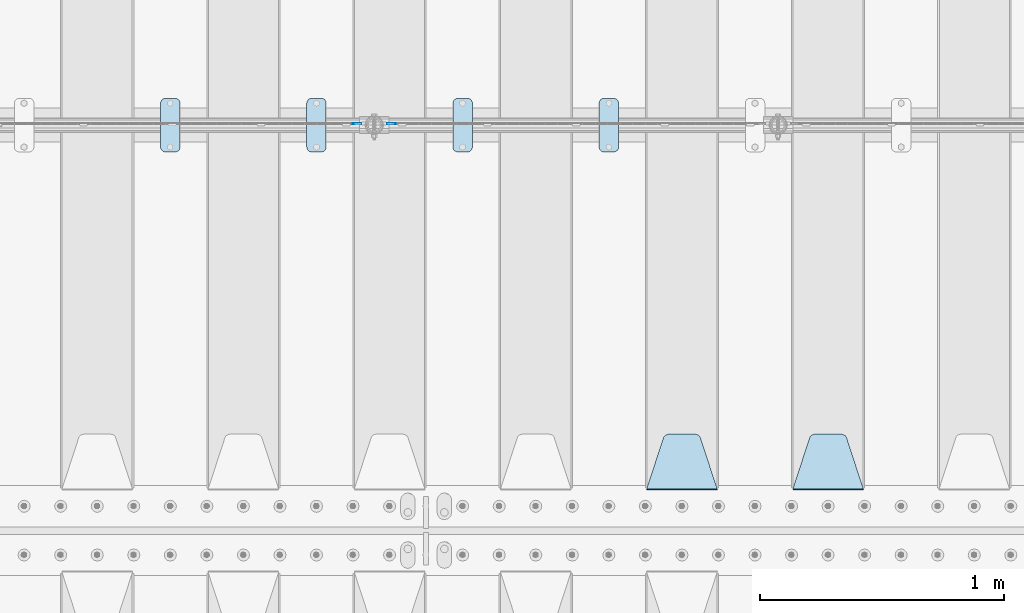
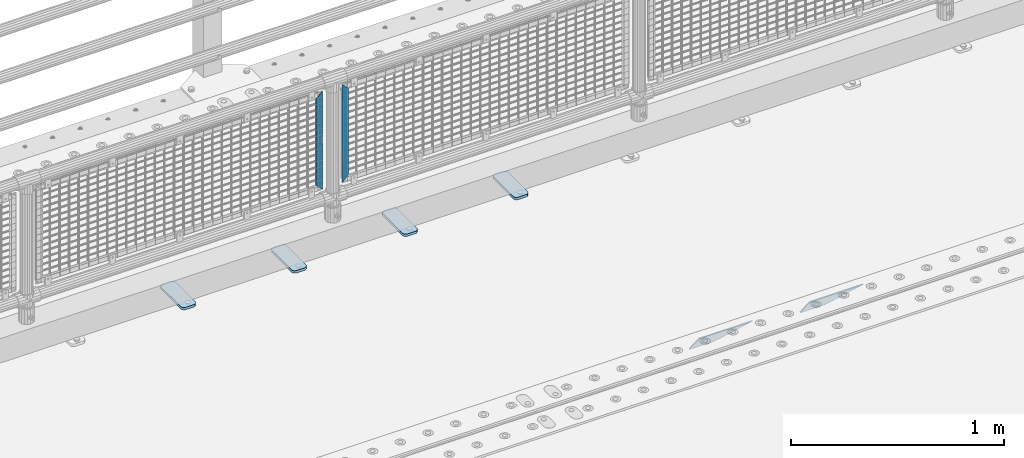
# One storey, part 161 of 193: 8 plates.
"""IFC2X3 building model written with IfcOpenShell, lengths in millimetres."""

from ifc_helpers import new_model, si_unit, frame, origin_with_axes, place, context, subcontext, project, spatial, faceted_brep, material, type_object, element, save


model = new_model("IFC2X3")

# Units and contexts
model_context = context("Model", 3, precision=1e-05, world=origin_with_axes())
body_context = subcontext(model_context, "Body", "Model", "MODEL_VIEW")
ifc_project = project(units=[si_unit("LENGTHUNIT", "METRE", prefix="MILLI"), si_unit("AREAUNIT", "SQUARE_METRE"), si_unit("VOLUMEUNIT", "CUBIC_METRE"), si_unit("MASSUNIT", "GRAM", prefix="KILO"), si_unit("TIMEUNIT", "SECOND"), si_unit("PLANEANGLEUNIT", "RADIAN"), si_unit("SOLIDANGLEUNIT", "STERADIAN"), si_unit("THERMODYNAMICTEMPERATUREUNIT", "DEGREE_CELSIUS"), si_unit("LUMINOUSINTENSITYUNIT", "LUMEN")], contexts=[model_context])

# Site, building, storey
site_placement = place(None, origin_with_axes())
site = spatial("IfcSite", under=ifc_project, at=site_placement, CompositionType="ELEMENT")
building_placement = place(site_placement, origin_with_axes())
building = spatial("IfcBuilding", under=site, at=building_placement, Name="Standard", CompositionType="ELEMENT")
storey_placement = place(building_placement, origin_with_axes())
storey = spatial("IfcBuildingStorey", under=building, at=storey_placement, Name="Undefined", CompositionType="ELEMENT", Elevation=0.0)

# Plates
ifc_material_1 = material(Name="STEEL/S355N")
plate_type_1 = type_object("IfcPlateType", PredefinedType="NOTDEFINED")
plate_1_placement = place(storey_placement, frame((-36505.0, 27168.232233047, -1.76776695296758), z_axis=(0.0, 0.707106781186547, -0.707106781186548), x_axis=(-1.0, 0.0, 0.0)))
element("IfcPlate", 1, at=plate_1_placement, inside=storey, type_object=plate_type_1, material=ifc_material_1, context=body_context, shape_type="Brep", body=[
    faceted_brep([(0.0, -2.5, 0.0), (69.345504679477, -2.50000000000364, 300.171731424831), (69.345504679477, 2.49999999999636, 300.171731424831), (0.0, 2.5, 0.0), (70.9274061199576, -2.50000000000364, 304.897442415397), (70.9274061199576, 2.49999999999636, 304.897442415397), (73.3818627772307, -2.50000000000364, 309.234538108529), (73.3818627772307, 2.49999999999636, 309.234538108529), (76.6187032999551, -2.50000000000728, 313.023683126103), (76.6187032999551, 2.49999999999636, 313.023683126103), (80.5190132704993, -2.50000000000364, 316.125672595372), (80.5190132704993, 2.49999999999636, 316.125672595368), (84.9395038596849, -2.50000000000364, 318.426546230472), (84.9395038596849, 2.49999999999636, 318.426546230476), (89.7177759439219, -2.50000000000364, 319.841774983273), (89.7177759439219, 2.49999999999636, 319.841774983277), (94.678286292652, -2.50000000000364, 320.319366455074), (94.678286292652, 2.49999999999636, 320.319366455074), (195.321713707348, -2.50000000000364, 320.319366455074), (195.321713707348, 2.49999999999636, 320.319366455074), (200.282224056078, -2.50000000000364, 319.841774983273), (200.282224056078, 2.49999999999636, 319.841774983277), (205.060496140315, -2.50000000000364, 318.426546230472), (205.060496140315, 2.49999999999636, 318.426546230472), (209.480986729501, -2.50000000000364, 316.125672595372), (209.480986729501, 2.49999999999636, 316.125672595368), (213.381296700045, -2.50000000000728, 313.023683126103), (213.381296700045, 2.49999999999272, 313.023683126103), (216.618137222769, -2.50000000000364, 309.234538108525), (216.618137222769, 2.49999999999636, 309.234538108522), (219.072593880042, -2.50000000000364, 304.897442415397), (219.072593880042, 2.49999999999636, 304.897442415397), (220.654495320523, -2.50000000000364, 300.171731424831), (220.654495320523, 2.49999999999636, 300.171731424831), (290.0, -2.50000000000364, 0.0), (290.0, 2.49999999999636, 0.0)], [[[0, 1, 2, 3]], [[1, 4, 5, 2]], [[4, 6, 7, 5]], [[6, 8, 9, 7]], [[8, 10, 11, 9]], [[10, 12, 13, 11]], [[12, 14, 15, 13]], [[14, 16, 17, 15]], [[16, 18, 19, 17]], [[18, 20, 21, 19]], [[20, 22, 23, 21]], [[22, 24, 25, 23]], [[24, 26, 27, 25]], [[26, 28, 29, 27]], [[28, 30, 31, 29]], [[30, 32, 33, 31]], [[32, 34, 35, 33]], [[34, 0, 3, 35]], [[5, 7, 9, 11, 13, 15, 17, 19, 21, 23, 25, 27, 29, 31, 33, 35, 3, 2]], [[34, 32, 30, 28, 26, 24, 22, 20, 18, 16, 14, 12, 10, 8, 6, 4, 1, 0]]]),
])
plate_2_placement = place(storey_placement, frame((-37105.0, 27168.232233047, -1.76776695296758), z_axis=(0.0, 0.707106781186547, -0.707106781186548), x_axis=(-1.0, 0.0, 0.0)))
element("IfcPlate", 2, at=plate_2_placement, inside=storey, type_object=plate_type_1, material=ifc_material_1, context=body_context, shape_type="Brep", body=[
    faceted_brep([(0.0, -2.5, 0.0), (69.345504679477, -2.50000000000364, 300.171731424831), (69.345504679477, 2.49999999999636, 300.171731424831), (0.0, 2.5, 0.0), (70.9274061199576, -2.50000000000364, 304.897442415397), (70.9274061199576, 2.49999999999636, 304.897442415397), (73.3818627772307, -2.50000000000364, 309.234538108529), (73.3818627772307, 2.49999999999636, 309.234538108529), (76.6187032999551, -2.50000000000728, 313.023683126103), (76.6187032999551, 2.49999999999636, 313.023683126103), (80.5190132704993, -2.50000000000364, 316.125672595372), (80.5190132704993, 2.49999999999636, 316.125672595368), (84.9395038596849, -2.50000000000364, 318.426546230472), (84.9395038596849, 2.49999999999636, 318.426546230476), (89.7177759439219, -2.50000000000364, 319.841774983273), (89.7177759439219, 2.49999999999636, 319.841774983277), (94.678286292652, -2.50000000000364, 320.319366455074), (94.678286292652, 2.49999999999636, 320.319366455074), (195.321713707348, -2.50000000000364, 320.319366455074), (195.321713707348, 2.49999999999636, 320.319366455074), (200.282224056078, -2.50000000000364, 319.841774983273), (200.282224056078, 2.49999999999636, 319.841774983277), (205.060496140315, -2.50000000000364, 318.426546230472), (205.060496140315, 2.49999999999636, 318.426546230472), (209.480986729501, -2.50000000000364, 316.125672595372), (209.480986729501, 2.49999999999636, 316.125672595368), (213.381296700045, -2.50000000000728, 313.023683126103), (213.381296700045, 2.49999999999272, 313.023683126103), (216.618137222769, -2.50000000000364, 309.234538108525), (216.618137222769, 2.49999999999636, 309.234538108522), (219.072593880042, -2.50000000000364, 304.897442415397), (219.072593880042, 2.49999999999636, 304.897442415397), (220.654495320523, -2.50000000000364, 300.171731424831), (220.654495320523, 2.49999999999636, 300.171731424831), (290.0, -2.50000000000364, 0.0), (290.0, 2.49999999999636, 0.0)], [[[0, 1, 2, 3]], [[1, 4, 5, 2]], [[4, 6, 7, 5]], [[6, 8, 9, 7]], [[8, 10, 11, 9]], [[10, 12, 13, 11]], [[12, 14, 15, 13]], [[14, 16, 17, 15]], [[16, 18, 19, 17]], [[18, 20, 21, 19]], [[20, 22, 23, 21]], [[22, 24, 25, 23]], [[24, 26, 27, 25]], [[26, 28, 29, 27]], [[28, 30, 31, 29]], [[30, 32, 33, 31]], [[32, 34, 35, 33]], [[34, 0, 3, 35]], [[5, 7, 9, 11, 13, 15, 17, 19, 21, 23, 25, 27, 29, 31, 33, 35, 3, 2]], [[34, 32, 30, 28, 26, 24, 22, 20, 18, 16, 14, 12, 10, 8, 6, 4, 1, 0]]]),
])
ifc_material_2 = material(Name="Misc_Undefined")
plate_type_2 = type_object("IfcPlateType", PredefinedType="NOTDEFINED")
plate_3_placement = place(storey_placement, frame((-38424.490286459, 28670.5, 879.519963133601), z_axis=(-0.707008801899319, 0.0, -0.707204746899291), x_axis=(-0.70720474689929, 0.0, 0.707008801899319)))
element("IfcPlate", 3, at=plate_3_placement, inside=storey, type_object=plate_type_2, material=ifc_material_2, context=body_context, shape_type="Brep", body=[
    faceted_brep([(0.0, -1.49999999999636, 3.63797880709171e-12), (-348.552185058594, -1.5, 348.655029296875), (-348.552185058594, 1.5, 348.655029296875), (0.0, 1.50000000000364, 7.27595761418343e-12), (-348.544891357422, -1.5, 398.152496337891), (-348.544891357422, 1.5, 398.152496337891), (49.50439453125, -1.5, 7.6397554948926e-11), (49.50439453125, 1.5, 7.6397554948926e-11)], [[[0, 1, 2, 3]], [[1, 4, 5, 2]], [[4, 6, 7, 5]], [[6, 0, 3, 7]], [[5, 7, 3, 2]], [[6, 4, 1, 0]]]),
])
plate_4_placement = place(storey_placement, frame((-38601.5003125164, 28670.5, 879.52), z_axis=(0.707103624179499, 0.0, -0.707109938179501), x_axis=(0.707109938179495, 0.0, 0.707103624179505)))
element("IfcPlate", 4, at=plate_4_placement, inside=storey, type_object=plate_type_2, material=ifc_material_2, context=body_context, shape_type="Brep", body=[
    faceted_brep([(0.0, -1.49999999999636, 3.63797880709171e-12), (-348.605163574215, -1.5, 348.602081298824), (-348.605163574215, 1.5, 348.602081298824), (0.0, 1.50000000000364, 7.27595761418343e-12), (-348.605163574215, -1.5, 398.099334716793), (-348.605163574215, 1.5, 398.099334716793), (49.4976959228552, -1.5, -1.01863406598568e-10), (49.4976959228552, 1.5, -1.01863406598568e-10)], [[[0, 1, 2, 3]], [[1, 4, 5, 2]], [[4, 6, 7, 5]], [[6, 0, 3, 7]], [[5, 7, 3, 2]], [[6, 4, 1, 0]]]),
])
ifc_material_3 = material(Name="STEEL/S355J2")
plate_type_3 = type_object("IfcPlateType", PredefinedType="NOTDEFINED")
plate_5_placement = place(storey_placement, frame((-37590.0, 28774.5, 21.0199999999977), z_axis=(1.0, 0.0, 0.0), x_axis=(0.0, -1.0, 0.0)))
element("IfcPlate", 5, at=plate_5_placement, inside=storey, type_object=plate_type_3, material=ifc_material_3, context=body_context, shape_type="Brep", body=[
    faceted_brep([(0.0, -7.0, 20.0), (0.0, -7.0, 60.0), (0.0, 7.0, 60.0), (0.0, 7.0, 20.0), (0.384294391937146, -7.0, 63.9018064403208), (0.384294391937146, 7.0, 63.9018064403208), (1.52240934977453, -7.0, 67.6536686473009), (1.52240934977453, 7.0, 67.6536686473009), (3.37060775395003, -7.0, 71.1114046603907), (3.37060775395003, 7.0, 71.1114046603907), (5.8578643762703, -7.0, 74.1421356237297), (5.8578643762703, 7.0, 74.1421356237297), (8.88859533960931, -7.0, 76.62939224605), (8.88859533960931, 7.0, 76.62939224605), (12.3463313526991, -7.0, 78.4775906502255), (12.3463313526991, 7.0, 78.4775906502255), (16.0981935596792, -7.0, 79.6157056080629), (16.0981935596792, 7.0, 79.6157056080629), (20.0, -7.0, 80.0), (20.0, 7.0, 80.0), (200.0, -7.0, 80.0), (200.0, 7.0, 80.0), (203.901806440321, -7.0, 79.6157056080629), (203.901806440321, 7.0, 79.6157056080629), (207.653668647301, -7.0, 78.4775906502255), (207.653668647301, 7.0, 78.4775906502255), (211.111404660391, -7.0, 76.62939224605), (211.111404660391, 7.0, 76.62939224605), (214.14213562373, -7.0, 74.1421356237297), (214.14213562373, 7.0, 74.1421356237297), (216.62939224605, -7.0, 71.1114046603907), (216.62939224605, 7.0, 71.1114046603907), (218.477590650225, -7.0, 67.6536686473009), (218.477590650225, 7.0, 67.6536686473009), (219.615705608063, -7.0, 63.9018064403208), (219.615705608063, 7.0, 63.9018064403208), (220.0, -7.0, 60.0), (220.0, 7.0, 60.0), (220.0, -7.0, 20.0), (220.0, 7.0, 20.0), (219.615705608063, -7.0, 16.0981935596792), (219.615705608063, 7.0, 16.0981935596792), (218.477590650225, -7.0, 12.3463313526991), (218.477590650225, 7.0, 12.3463313526991), (216.62939224605, -7.0, 8.88859533960931), (216.62939224605, 7.0, 8.88859533960931), (214.14213562373, -7.0, 5.8578643762703), (214.14213562373, 7.0, 5.8578643762703), (211.111404660391, -7.0, 3.37060775395003), (211.111404660391, 7.0, 3.37060775395003), (207.653668647301, -7.0, 1.52240934977453), (207.653668647301, 7.0, 1.52240934977453), (203.901806440321, -7.0, 0.384294391937146), (203.901806440321, 7.0, 0.384294391937146), (200.0, -7.0, 0.0), (200.0, 7.0, 0.0), (20.0, -7.0, 0.0), (20.0, 7.0, 0.0), (16.0981935596792, -7.0, 0.384294391937146), (16.0981935596792, 7.0, 0.384294391937146), (12.3463313526991, -7.0, 1.52240934977453), (12.3463313526991, 7.0, 1.52240934977453), (8.88859533960931, -7.0, 3.37060775395003), (8.88859533960931, 7.0, 3.37060775395003), (5.8578643762703, -7.0, 5.8578643762703), (5.8578643762703, 7.0, 5.8578643762703), (3.37060775395003, -7.0, 8.88859533960931), (3.37060775395003, 7.0, 8.88859533960931), (1.52240934977453, -7.0, 12.3463313526991), (1.52240934977453, 7.0, 12.3463313526991), (0.384294391937146, -7.0, 16.0981935596792), (0.384294391937146, 7.0, 16.0981935596792)], [[[0, 1, 2, 3]], [[1, 4, 5, 2]], [[4, 6, 7, 5]], [[6, 8, 9, 7]], [[8, 10, 11, 9]], [[10, 12, 13, 11]], [[12, 14, 15, 13]], [[14, 16, 17, 15]], [[16, 18, 19, 17]], [[18, 20, 21, 19]], [[20, 22, 23, 21]], [[22, 24, 25, 23]], [[24, 26, 27, 25]], [[26, 28, 29, 27]], [[28, 30, 31, 29]], [[30, 32, 33, 31]], [[32, 34, 35, 33]], [[34, 36, 37, 35]], [[36, 38, 39, 37]], [[38, 40, 41, 39]], [[40, 42, 43, 41]], [[42, 44, 45, 43]], [[44, 46, 47, 45]], [[46, 48, 49, 47]], [[48, 50, 51, 49]], [[50, 52, 53, 51]], [[52, 54, 55, 53]], [[54, 56, 57, 55]], [[56, 58, 59, 57]], [[58, 60, 61, 59]], [[60, 62, 63, 61]], [[62, 64, 65, 63]], [[64, 66, 67, 65]], [[66, 68, 69, 67]], [[68, 70, 71, 69]], [[70, 0, 3, 71]], [[5, 7, 9, 11, 13, 15, 17, 19, 21, 23, 25, 27, 29, 31, 33, 35, 37, 39, 41, 43, 45, 47, 49, 51, 53, 55, 57, 59, 61, 63, 65, 67, 69, 71, 3, 2]], [[70, 68, 66, 64, 62, 60, 58, 56, 54, 52, 50, 48, 46, 44, 42, 40, 38, 36, 34, 32, 30, 28, 26, 24, 22, 20, 18, 16, 14, 12, 10, 8, 6, 4, 1, 0]]]),
])
plate_6_placement = place(storey_placement, frame((-38190.0, 28774.5, 21.0199999999977), z_axis=(1.0, 0.0, 0.0), x_axis=(0.0, -1.0, 0.0)))
element("IfcPlate", 6, at=plate_6_placement, inside=storey, type_object=plate_type_3, material=ifc_material_3, context=body_context, shape_type="Brep", body=[
    faceted_brep([(0.0, -7.0, 20.0), (0.0, -7.0, 60.0), (0.0, 7.0, 60.0), (0.0, 7.0, 20.0), (0.384294391937146, -7.0, 63.9018064403208), (0.384294391937146, 7.0, 63.9018064403208), (1.52240934977453, -7.0, 67.6536686473009), (1.52240934977453, 7.0, 67.6536686473009), (3.37060775395003, -7.0, 71.1114046603907), (3.37060775395003, 7.0, 71.1114046603907), (5.8578643762703, -7.0, 74.1421356237297), (5.8578643762703, 7.0, 74.1421356237297), (8.88859533960931, -7.0, 76.62939224605), (8.88859533960931, 7.0, 76.62939224605), (12.3463313526991, -7.0, 78.4775906502255), (12.3463313526991, 7.0, 78.4775906502255), (16.0981935596792, -7.0, 79.6157056080629), (16.0981935596792, 7.0, 79.6157056080629), (20.0, -7.0, 80.0), (20.0, 7.0, 80.0), (200.0, -7.0, 80.0), (200.0, 7.0, 80.0), (203.901806440321, -7.0, 79.6157056080629), (203.901806440321, 7.0, 79.6157056080629), (207.653668647301, -7.0, 78.4775906502255), (207.653668647301, 7.0, 78.4775906502255), (211.111404660391, -7.0, 76.62939224605), (211.111404660391, 7.0, 76.62939224605), (214.14213562373, -7.0, 74.1421356237297), (214.14213562373, 7.0, 74.1421356237297), (216.62939224605, -7.0, 71.1114046603907), (216.62939224605, 7.0, 71.1114046603907), (218.477590650225, -7.0, 67.6536686473009), (218.477590650225, 7.0, 67.6536686473009), (219.615705608063, -7.0, 63.9018064403208), (219.615705608063, 7.0, 63.9018064403208), (220.0, -7.0, 60.0), (220.0, 7.0, 60.0), (220.0, -7.0, 20.0), (220.0, 7.0, 20.0), (219.615705608063, -7.0, 16.0981935596792), (219.615705608063, 7.0, 16.0981935596792), (218.477590650225, -7.0, 12.3463313526991), (218.477590650225, 7.0, 12.3463313526991), (216.62939224605, -7.0, 8.88859533960931), (216.62939224605, 7.0, 8.88859533960931), (214.14213562373, -7.0, 5.8578643762703), (214.14213562373, 7.0, 5.8578643762703), (211.111404660391, -7.0, 3.37060775395003), (211.111404660391, 7.0, 3.37060775395003), (207.653668647301, -7.0, 1.52240934977453), (207.653668647301, 7.0, 1.52240934977453), (203.901806440321, -7.0, 0.384294391937146), (203.901806440321, 7.0, 0.384294391937146), (200.0, -7.0, 0.0), (200.0, 7.0, 0.0), (20.0, -7.0, 0.0), (20.0, 7.0, 0.0), (16.0981935596792, -7.0, 0.384294391937146), (16.0981935596792, 7.0, 0.384294391937146), (12.3463313526991, -7.0, 1.52240934977453), (12.3463313526991, 7.0, 1.52240934977453), (8.88859533960931, -7.0, 3.37060775395003), (8.88859533960931, 7.0, 3.37060775395003), (5.8578643762703, -7.0, 5.8578643762703), (5.8578643762703, 7.0, 5.8578643762703), (3.37060775395003, -7.0, 8.88859533960931), (3.37060775395003, 7.0, 8.88859533960931), (1.52240934977453, -7.0, 12.3463313526991), (1.52240934977453, 7.0, 12.3463313526991), (0.384294391937146, -7.0, 16.0981935596792), (0.384294391937146, 7.0, 16.0981935596792)], [[[0, 1, 2, 3]], [[1, 4, 5, 2]], [[4, 6, 7, 5]], [[6, 8, 9, 7]], [[8, 10, 11, 9]], [[10, 12, 13, 11]], [[12, 14, 15, 13]], [[14, 16, 17, 15]], [[16, 18, 19, 17]], [[18, 20, 21, 19]], [[20, 22, 23, 21]], [[22, 24, 25, 23]], [[24, 26, 27, 25]], [[26, 28, 29, 27]], [[28, 30, 31, 29]], [[30, 32, 33, 31]], [[32, 34, 35, 33]], [[34, 36, 37, 35]], [[36, 38, 39, 37]], [[38, 40, 41, 39]], [[40, 42, 43, 41]], [[42, 44, 45, 43]], [[44, 46, 47, 45]], [[46, 48, 49, 47]], [[48, 50, 51, 49]], [[50, 52, 53, 51]], [[52, 54, 55, 53]], [[54, 56, 57, 55]], [[56, 58, 59, 57]], [[58, 60, 61, 59]], [[60, 62, 63, 61]], [[62, 64, 65, 63]], [[64, 66, 67, 65]], [[66, 68, 69, 67]], [[68, 70, 71, 69]], [[70, 0, 3, 71]], [[5, 7, 9, 11, 13, 15, 17, 19, 21, 23, 25, 27, 29, 31, 33, 35, 37, 39, 41, 43, 45, 47, 49, 51, 53, 55, 57, 59, 61, 63, 65, 67, 69, 71, 3, 2]], [[70, 68, 66, 64, 62, 60, 58, 56, 54, 52, 50, 48, 46, 44, 42, 40, 38, 36, 34, 32, 30, 28, 26, 24, 22, 20, 18, 16, 14, 12, 10, 8, 6, 4, 1, 0]]]),
])
plate_7_placement = place(storey_placement, frame((-38790.0, 28774.5, 21.0199999999977), z_axis=(1.0, 0.0, 0.0), x_axis=(0.0, -1.0, 0.0)))
element("IfcPlate", 7, at=plate_7_placement, inside=storey, type_object=plate_type_3, material=ifc_material_3, context=body_context, shape_type="Brep", body=[
    faceted_brep([(0.0, -7.0, 20.0), (0.0, -7.0, 60.0), (0.0, 7.0, 60.0), (0.0, 7.0, 20.0), (0.384294391937146, -7.0, 63.9018064403208), (0.384294391937146, 7.0, 63.9018064403208), (1.52240934977453, -7.0, 67.6536686473009), (1.52240934977453, 7.0, 67.6536686473009), (3.37060775395003, -7.0, 71.1114046603907), (3.37060775395003, 7.0, 71.1114046603907), (5.8578643762703, -7.0, 74.1421356237297), (5.8578643762703, 7.0, 74.1421356237297), (8.88859533960931, -7.0, 76.62939224605), (8.88859533960931, 7.0, 76.62939224605), (12.3463313526991, -7.0, 78.4775906502255), (12.3463313526991, 7.0, 78.4775906502255), (16.0981935596792, -7.0, 79.6157056080629), (16.0981935596792, 7.0, 79.6157056080629), (20.0, -7.0, 80.0), (20.0, 7.0, 80.0), (200.0, -7.0, 80.0), (200.0, 7.0, 80.0), (203.901806440321, -7.0, 79.6157056080629), (203.901806440321, 7.0, 79.6157056080629), (207.653668647301, -7.0, 78.4775906502255), (207.653668647301, 7.0, 78.4775906502255), (211.111404660391, -7.0, 76.62939224605), (211.111404660391, 7.0, 76.62939224605), (214.14213562373, -7.0, 74.1421356237297), (214.14213562373, 7.0, 74.1421356237297), (216.62939224605, -7.0, 71.1114046603907), (216.62939224605, 7.0, 71.1114046603907), (218.477590650225, -7.0, 67.6536686473009), (218.477590650225, 7.0, 67.6536686473009), (219.615705608063, -7.0, 63.9018064403208), (219.615705608063, 7.0, 63.9018064403208), (220.0, -7.0, 60.0), (220.0, 7.0, 60.0), (220.0, -7.0, 20.0), (220.0, 7.0, 20.0), (219.615705608063, -7.0, 16.0981935596792), (219.615705608063, 7.0, 16.0981935596792), (218.477590650225, -7.0, 12.3463313526991), (218.477590650225, 7.0, 12.3463313526991), (216.62939224605, -7.0, 8.88859533960931), (216.62939224605, 7.0, 8.88859533960931), (214.14213562373, -7.0, 5.8578643762703), (214.14213562373, 7.0, 5.8578643762703), (211.111404660391, -7.0, 3.37060775395003), (211.111404660391, 7.0, 3.37060775395003), (207.653668647301, -7.0, 1.52240934977453), (207.653668647301, 7.0, 1.52240934977453), (203.901806440321, -7.0, 0.384294391937146), (203.901806440321, 7.0, 0.384294391937146), (200.0, -7.0, 0.0), (200.0, 7.0, 0.0), (20.0, -7.0, 0.0), (20.0, 7.0, 0.0), (16.0981935596792, -7.0, 0.384294391937146), (16.0981935596792, 7.0, 0.384294391937146), (12.3463313526991, -7.0, 1.52240934977453), (12.3463313526991, 7.0, 1.52240934977453), (8.88859533960931, -7.0, 3.37060775395003), (8.88859533960931, 7.0, 3.37060775395003), (5.8578643762703, -7.0, 5.8578643762703), (5.8578643762703, 7.0, 5.8578643762703), (3.37060775395003, -7.0, 8.88859533960931), (3.37060775395003, 7.0, 8.88859533960931), (1.52240934977453, -7.0, 12.3463313526991), (1.52240934977453, 7.0, 12.3463313526991), (0.384294391937146, -7.0, 16.0981935596792), (0.384294391937146, 7.0, 16.0981935596792)], [[[0, 1, 2, 3]], [[1, 4, 5, 2]], [[4, 6, 7, 5]], [[6, 8, 9, 7]], [[8, 10, 11, 9]], [[10, 12, 13, 11]], [[12, 14, 15, 13]], [[14, 16, 17, 15]], [[16, 18, 19, 17]], [[18, 20, 21, 19]], [[20, 22, 23, 21]], [[22, 24, 25, 23]], [[24, 26, 27, 25]], [[26, 28, 29, 27]], [[28, 30, 31, 29]], [[30, 32, 33, 31]], [[32, 34, 35, 33]], [[34, 36, 37, 35]], [[36, 38, 39, 37]], [[38, 40, 41, 39]], [[40, 42, 43, 41]], [[42, 44, 45, 43]], [[44, 46, 47, 45]], [[46, 48, 49, 47]], [[48, 50, 51, 49]], [[50, 52, 53, 51]], [[52, 54, 55, 53]], [[54, 56, 57, 55]], [[56, 58, 59, 57]], [[58, 60, 61, 59]], [[60, 62, 63, 61]], [[62, 64, 65, 63]], [[64, 66, 67, 65]], [[66, 68, 69, 67]], [[68, 70, 71, 69]], [[70, 0, 3, 71]], [[5, 7, 9, 11, 13, 15, 17, 19, 21, 23, 25, 27, 29, 31, 33, 35, 37, 39, 41, 43, 45, 47, 49, 51, 53, 55, 57, 59, 61, 63, 65, 67, 69, 71, 3, 2]], [[70, 68, 66, 64, 62, 60, 58, 56, 54, 52, 50, 48, 46, 44, 42, 40, 38, 36, 34, 32, 30, 28, 26, 24, 22, 20, 18, 16, 14, 12, 10, 8, 6, 4, 1, 0]]]),
])
plate_8_placement = place(storey_placement, frame((-39390.0, 28774.5, 21.0199999999977), z_axis=(1.0, 0.0, 0.0), x_axis=(0.0, -1.0, 0.0)))
element("IfcPlate", 8, at=plate_8_placement, inside=storey, type_object=plate_type_3, material=ifc_material_3, context=body_context, shape_type="Brep", body=[
    faceted_brep([(0.0, -7.0, 20.0), (0.0, -7.0, 60.0), (0.0, 7.0, 60.0), (0.0, 7.0, 20.0), (0.384294391937146, -7.0, 63.9018064403208), (0.384294391937146, 7.0, 63.9018064403208), (1.52240934977453, -7.0, 67.6536686473009), (1.52240934977453, 7.0, 67.6536686473009), (3.37060775395003, -7.0, 71.1114046603907), (3.37060775395003, 7.0, 71.1114046603907), (5.8578643762703, -7.0, 74.1421356237297), (5.8578643762703, 7.0, 74.1421356237297), (8.88859533960931, -7.0, 76.62939224605), (8.88859533960931, 7.0, 76.62939224605), (12.3463313526991, -7.0, 78.4775906502255), (12.3463313526991, 7.0, 78.4775906502255), (16.0981935596792, -7.0, 79.6157056080629), (16.0981935596792, 7.0, 79.6157056080629), (20.0, -7.0, 80.0), (20.0, 7.0, 80.0), (200.0, -7.0, 80.0), (200.0, 7.0, 80.0), (203.901806440321, -7.0, 79.6157056080629), (203.901806440321, 7.0, 79.6157056080629), (207.653668647301, -7.0, 78.4775906502255), (207.653668647301, 7.0, 78.4775906502255), (211.111404660391, -7.0, 76.62939224605), (211.111404660391, 7.0, 76.62939224605), (214.14213562373, -7.0, 74.1421356237297), (214.14213562373, 7.0, 74.1421356237297), (216.62939224605, -7.0, 71.1114046603907), (216.62939224605, 7.0, 71.1114046603907), (218.477590650225, -7.0, 67.6536686473009), (218.477590650225, 7.0, 67.6536686473009), (219.615705608063, -7.0, 63.9018064403208), (219.615705608063, 7.0, 63.9018064403208), (220.0, -7.0, 60.0), (220.0, 7.0, 60.0), (220.0, -7.0, 20.0), (220.0, 7.0, 20.0), (219.615705608063, -7.0, 16.0981935596792), (219.615705608063, 7.0, 16.0981935596792), (218.477590650225, -7.0, 12.3463313526991), (218.477590650225, 7.0, 12.3463313526991), (216.62939224605, -7.0, 8.88859533960931), (216.62939224605, 7.0, 8.88859533960931), (214.14213562373, -7.0, 5.8578643762703), (214.14213562373, 7.0, 5.8578643762703), (211.111404660391, -7.0, 3.37060775395003), (211.111404660391, 7.0, 3.37060775395003), (207.653668647301, -7.0, 1.52240934977453), (207.653668647301, 7.0, 1.52240934977453), (203.901806440321, -7.0, 0.384294391937146), (203.901806440321, 7.0, 0.384294391937146), (200.0, -7.0, 0.0), (200.0, 7.0, 0.0), (20.0, -7.0, 0.0), (20.0, 7.0, 0.0), (16.0981935596792, -7.0, 0.384294391937146), (16.0981935596792, 7.0, 0.384294391937146), (12.3463313526991, -7.0, 1.52240934977453), (12.3463313526991, 7.0, 1.52240934977453), (8.88859533960931, -7.0, 3.37060775395003), (8.88859533960931, 7.0, 3.37060775395003), (5.8578643762703, -7.0, 5.8578643762703), (5.8578643762703, 7.0, 5.8578643762703), (3.37060775395003, -7.0, 8.88859533960931), (3.37060775395003, 7.0, 8.88859533960931), (1.52240934977453, -7.0, 12.3463313526991), (1.52240934977453, 7.0, 12.3463313526991), (0.384294391937146, -7.0, 16.0981935596792), (0.384294391937146, 7.0, 16.0981935596792)], [[[0, 1, 2, 3]], [[1, 4, 5, 2]], [[4, 6, 7, 5]], [[6, 8, 9, 7]], [[8, 10, 11, 9]], [[10, 12, 13, 11]], [[12, 14, 15, 13]], [[14, 16, 17, 15]], [[16, 18, 19, 17]], [[18, 20, 21, 19]], [[20, 22, 23, 21]], [[22, 24, 25, 23]], [[24, 26, 27, 25]], [[26, 28, 29, 27]], [[28, 30, 31, 29]], [[30, 32, 33, 31]], [[32, 34, 35, 33]], [[34, 36, 37, 35]], [[36, 38, 39, 37]], [[38, 40, 41, 39]], [[40, 42, 43, 41]], [[42, 44, 45, 43]], [[44, 46, 47, 45]], [[46, 48, 49, 47]], [[48, 50, 51, 49]], [[50, 52, 53, 51]], [[52, 54, 55, 53]], [[54, 56, 57, 55]], [[56, 58, 59, 57]], [[58, 60, 61, 59]], [[60, 62, 63, 61]], [[62, 64, 65, 63]], [[64, 66, 67, 65]], [[66, 68, 69, 67]], [[68, 70, 71, 69]], [[70, 0, 3, 71]], [[5, 7, 9, 11, 13, 15, 17, 19, 21, 23, 25, 27, 29, 31, 33, 35, 37, 39, 41, 43, 45, 47, 49, 51, 53, 55, 57, 59, 61, 63, 65, 67, 69, 71, 3, 2]], [[70, 68, 66, 64, 62, 60, 58, 56, 54, 52, 50, 48, 46, 44, 42, 40, 38, 36, 34, 32, 30, 28, 26, 24, 22, 20, 18, 16, 14, 12, 10, 8, 6, 4, 1, 0]]]),
])

save(model, "model.ifc")
